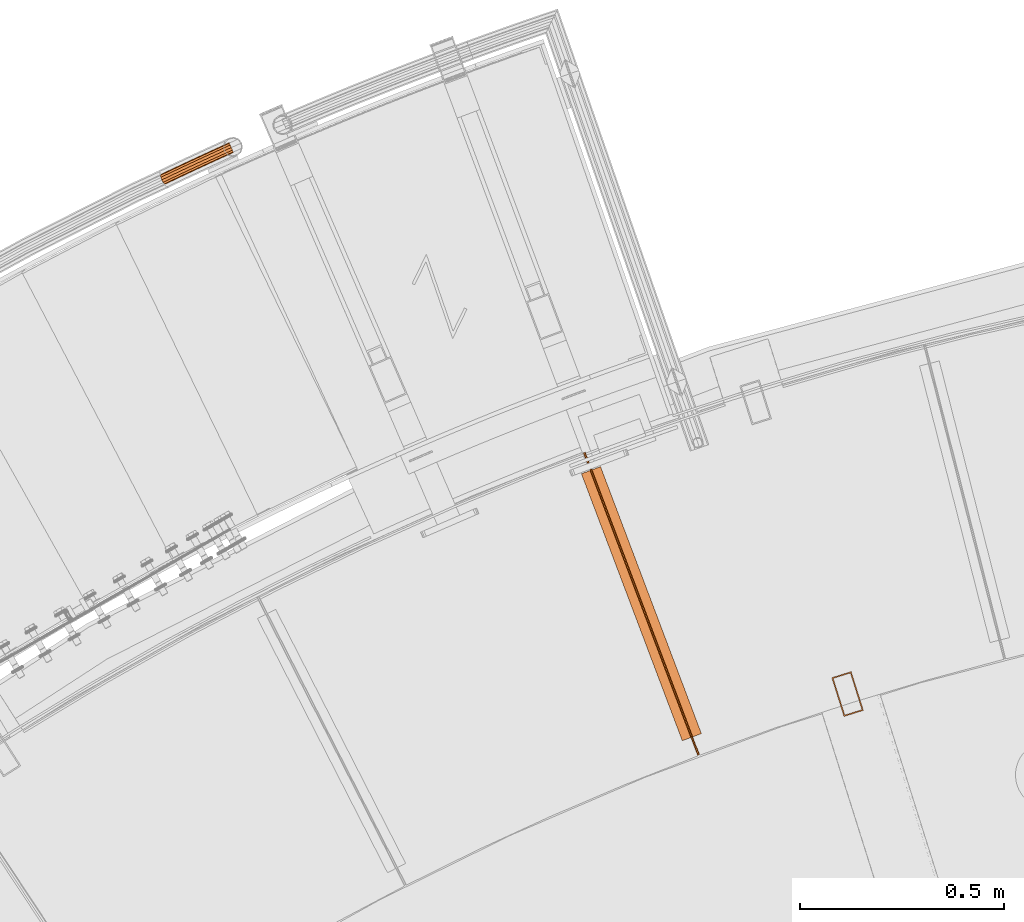
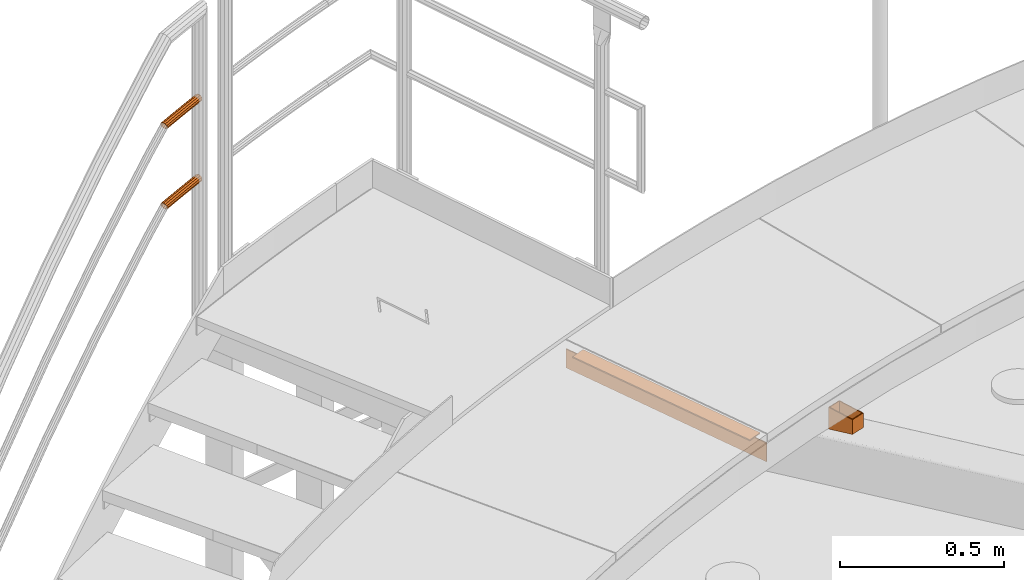
# One storey, part 85 of 126: 5 proxies.
"""IFC2X3 building model written with IfcOpenShell, lengths in millimetres."""

import ifcopenshell
import ifcopenshell.guid

model = None  # the IFC model being written
_history = None  # IfcOwnerHistory: only IFC2X3 demands one
_inside = {}  # id of a spatial element -> (the spatial element, [elements in it])
_under = {}  # id of a project, library or spatial element -> (it, [spatial elements below it])
_declared = {}  # id of a project -> (the project, [libraries it declares])
_typed = {}  # id of a type object -> (the type object, [elements of that type])
_made_of = {}  # id of a material, layer set ... -> (it, [elements and type objects made of it])


def new_model(schema):
    """Start an empty IFC model of exactly this schema.

    Asked for "IFC4X3", IfcOpenShell would pick the latest addendum, in which some entities
    have other attributes; the version numbers below select the first issue.
    IFC2X3 requires an IfcOwnerHistory on every rooted entity: one is made here for all.
    """
    global model, _history
    if schema == "IFC4X3":
        model = ifcopenshell.file(schema_version=(4, 3, 0, 0))
    else:
        model = ifcopenshell.file(schema=schema)
    _inside.clear()
    _under.clear()
    _declared.clear()
    _typed.clear()
    _made_of.clear()
    _history = None
    if model.schema == "IFC2X3":
        org = make("IfcOrganization", Name="unknown")
        user = make(
            "IfcPersonAndOrganization",
            ThePerson=make("IfcPerson", FamilyName="unknown"),
            TheOrganization=org,
        )
        app = make(
            "IfcApplication",
            ApplicationDeveloper=org,
            Version="unknown",
            ApplicationFullName="unknown",
            ApplicationIdentifier="unknown",
        )
        _history = make(
            "IfcOwnerHistory",
            OwningUser=user,
            OwningApplication=app,
            ChangeAction="ADDED",
            CreationDate=0,
        )
    return model


def make(cls, **values):
    """One entity of the class cls with the attributes given. An attribute that is None is left unset."""
    return model.create_entity(
        cls, **{name: value for name, value in values.items() if value is not None}
    )


def rooted(cls, **values):
    """An entity with a GlobalId (a new one), such as an element, a storey or a relation."""
    return make(cls, GlobalId=ifcopenshell.guid.new(), OwnerHistory=_history, **values)


def si_unit(unit_type, name, prefix=None):
    """IfcSIUnit, for example si_unit("LENGTHUNIT", "METRE", prefix="MILLI")."""
    return make("IfcSIUnit", UnitType=unit_type, Prefix=prefix, Name=name)


def assignment(units):
    """IfcUnitAssignment: the units of a project."""
    return None if units is None else make("IfcUnitAssignment", Units=units)


def point(xyz):
    """IfcCartesianPoint."""
    return None if xyz is None else make("IfcCartesianPoint", Coordinates=xyz)


def direction(xyz):
    """IfcDirection."""
    return None if xyz is None else make("IfcDirection", DirectionRatios=xyz)


def frame(location, z_axis=None, x_axis=None):
    """IfcAxis2Placement3D, a coordinate frame: its origin and axes. An axis left out is left unset."""
    return make(
        "IfcAxis2Placement3D",
        Location=point(location),
        Axis=direction(z_axis),
        RefDirection=direction(x_axis),
    )


def origin():
    """The frame at (0, 0, 0) with its axes left unset."""
    return frame((0.0, 0.0, 0.0))


def origin_with_axes():
    """The frame at (0, 0, 0) with the z axis (0, 0, 1) and the x axis (1, 0, 0) written out."""
    return frame((0.0, 0.0, 0.0), z_axis=(0.0, 0.0, 1.0), x_axis=(1.0, 0.0, 0.0))


def place(relative_to, where):
    """IfcLocalPlacement: puts the frame where relative to a parent placement (None: the world)."""
    return make(
        "IfcLocalPlacement", PlacementRelTo=relative_to, RelativePlacement=where
    )


def context(
    kind, dimensions, precision=None, world=None, true_north=None, identifier=None
):
    """IfcGeometricRepresentationContext, for example the 3D "Model" context."""
    return make(
        "IfcGeometricRepresentationContext",
        ContextIdentifier=identifier,
        ContextType=kind,
        CoordinateSpaceDimension=dimensions,
        Precision=precision,
        WorldCoordinateSystem=world,
        TrueNorth=true_north,
    )


def project(units=None, contexts=None):
    """IfcProject with its units and contexts."""
    return rooted(
        "IfcProject",
        Name="project",
        RepresentationContexts=contexts,
        UnitsInContext=assignment(units),
    )


def spatial(cls, under=None, at=None, **own):
    """A site, building, storey or space (cls), placed at a placement, below another one or the project."""
    s = rooted(cls, ObjectPlacement=at, **own)
    if under is not None:
        _under.setdefault(under.id(), (under, []))[1].append(s)
    return s


def faces_of(points, faces, orient=None, outer=None):
    """IfcFace entities. A face is a list of loops; a loop is a list of indices into points, from 0.

    orient and outer hold one flag for each loop. By default every Orientation is true, the
    first loop of a face is its IfcFaceOuterBound and the others are IfcFaceBound.
    """
    made = []
    for i, loops in enumerate(faces):
        bounds = []
        for j, loop in enumerate(loops):
            is_outer = j == 0 if outer is None else outer[i][j]
            bounds.append(
                make(
                    "IfcFaceOuterBound" if is_outer else "IfcFaceBound",
                    Bound=make("IfcPolyLoop", Polygon=[points[k] for k in loop]),
                    Orientation=True if orient is None else orient[i][j],
                )
            )
        made.append(make("IfcFace", Bounds=bounds))
    return made


def faceted_brep(points, faces, orient=None, outer=None, voids=None):
    """IfcFacetedBrep: a solid bounded by flat faces; with voids (closed shells), ...WithVoids."""
    shared = [point(p) for p in points]
    hull = make("IfcClosedShell", CfsFaces=faces_of(shared, faces, orient, outer))
    if voids is None:
        return make("IfcFacetedBrep", Outer=hull)
    return make(
        "IfcFacetedBrepWithVoids",
        Outer=hull,
        Voids=[
            make(cls, CfsFaces=faces_of(shared, fs, o, b)) for cls, fs, o, b in voids
        ],
    )


def shape(context_of_items, identifier, shape_type, items):
    """IfcShapeRepresentation: the items that make up one representation, for example the "Body"."""
    return make(
        "IfcShapeRepresentation",
        ContextOfItems=context_of_items,
        RepresentationIdentifier=identifier,
        RepresentationType=shape_type,
        Items=items,
    )


def material(Name=None, Category=None):
    """IfcMaterial."""
    return make("IfcMaterial", Name=Name, Category=Category)


def made_of(thing, what):
    """Note that an element or type object is made of a material, layer set ...; save() writes the relation."""
    if what is not None:
        _made_of.setdefault(what.id(), (what, []))[1].append(thing)
    return thing


def element(
    cls,
    number,
    at=None,
    inside=None,
    cuts=None,
    type_object=None,
    material=None,
    context=None,
    identifier="Body",
    shape_type=None,
    held_by="IfcProductDefinitionShape",
    body=None,
    shapes=None,
    **own,
):
    """One element of the class cls, such as IfcWall. Its Tag is "e" and its number.

    at: its placement. inside: the storey or other place that contains it. cuts: it is an
    opening in that element (IfcRelVoidsElement). A single representation is given by context,
    identifier, shape_type and body (its items); several are given by shapes. held_by: the class
    of the entity that holds the representations. save() writes the other relations.
    """
    e = rooted(cls, Tag="e%d" % number, ObjectPlacement=at, **own)
    if body is not None:
        shapes = [shape(context, identifier, shape_type, body)]
    if shapes is not None:
        e.Representation = make(held_by, Representations=shapes)
    if inside is not None:
        _inside.setdefault(inside.id(), (inside, []))[1].append(e)
    if cuts is not None:
        rooted(
            "IfcRelVoidsElement", RelatingBuildingElement=cuts, RelatedOpeningElement=e
        )
    if type_object is not None:
        _typed.setdefault(type_object.id(), (type_object, []))[1].append(e)
    return made_of(e, material)


def aggregate(whole, parts):
    """IfcRelAggregates: a whole, such as a stair, and the parts it consists of."""
    return rooted("IfcRelAggregates", RelatingObject=whole, RelatedObjects=parts)


def save(model, path):
    """Write the relations noted so far, then the file.

    IfcRelAggregates (storeys below a building ...), IfcRelContainedInSpatialStructure (elements
    in a storey), IfcRelDefinesByType, IfcRelAssociatesMaterial and IfcRelDeclares: one each for
    every whole, place, type object, material and project.
    """
    for whole, parts in _under.values():
        aggregate(whole, parts)
    for where, things in _inside.values():
        rooted(
            "IfcRelContainedInSpatialStructure",
            RelatedElements=things,
            RelatingStructure=where,
        )
    for kind, things in _typed.values():
        rooted("IfcRelDefinesByType", RelatedObjects=things, RelatingType=kind)
    for what, things in _made_of.values():
        rooted("IfcRelAssociatesMaterial", RelatedObjects=things, RelatingMaterial=what)
    for by, libraries in _declared.values():
        rooted("IfcRelDeclares", RelatingContext=by, RelatedDefinitions=libraries)
    model.write(path)


model = new_model("IFC2X3")

# Units and contexts
context_of_model_1 = context(None, 3, precision=0.1, world=origin())
context_of_model_2 = context(None, 3, precision=0.1, world=origin())
ifc_project = project(units=[si_unit("LENGTHUNIT", "METRE", prefix="MILLI"), si_unit("AREAUNIT", "SQUARE_METRE", prefix="CENTI"), si_unit("VOLUMEUNIT", "CUBIC_METRE", prefix="CENTI"), si_unit("MASSUNIT", "GRAM", prefix="KILO")], contexts=[context_of_model_1, context_of_model_2])

# Site, building, storey
site_placement = place(None, origin_with_axes())
site = spatial("IfcSite", under=ifc_project, at=site_placement, CompositionType="ELEMENT")
building_placement = place(site_placement, origin_with_axes())
building = spatial("IfcBuilding", under=site, at=building_placement, CompositionType="ELEMENT")
storey_placement = place(building_placement, origin_with_axes())
storey = spatial("IfcBuildingStorey", under=building, at=storey_placement, CompositionType="ELEMENT")

# Proxies
ifc_material_1 = material(Name="STAHL")
proxy_1_placement = place(storey_placement, origin_with_axes())
element("IfcBuildingElementProxy", 1, at=proxy_1_placement, inside=storey, material=ifc_material_1, Name="profile", context=context_of_model_2, shape_type="Brep", body=[
    faceted_brep([(5840.1, 14788.1, 10873.4), (5870.1, 14692.7, 10900.2), (5870.1, 14692.7, 10955.2), (5840.1, 14788.1, 10955.2), (5917.8, 14707.8, 10900.2), (5917.8, 14707.8, 10955.2), (5887.8, 14803.1, 10873.4), (5887.8, 14803.1, 10955.2), (5872.1, 14696.5, 10899.4), (5843.8, 14786.2, 10874.2), (5843.8, 14786.2, 10955.2), (5872.1, 14696.5, 10955.2), (5885.8, 14799.4, 10874.2), (5885.8, 14799.4, 10955.2), (5914.1, 14709.7, 10899.4), (5914.1, 14709.7, 10955.2)], [[[0, 1, 2, 3]], [[1, 4, 5, 2]], [[4, 6, 7, 5]], [[6, 0, 3, 7]], [[8, 9, 10, 11]], [[9, 12, 13, 10]], [[12, 14, 15, 13]], [[14, 8, 11, 15]], [[1, 0, 6, 4], [9, 8, 14, 12]], [[2, 5, 7, 3], [15, 11, 10, 13]]]),
])
proxy_2_placement = place(storey_placement, origin_with_axes())
element("IfcBuildingElementProxy", 2, at=proxy_2_placement, inside=storey, material=ifc_material_1, Name="profile", context=context_of_model_2, shape_type="Brep", body=[
    faceted_brep([(5515.2, 14599.7, 11051.2), (5515.2, 14599.7, 10981.2), (5235.3, 15340.5, 10981.2), (5235.3, 15340.5, 11051.2), (5511.5, 14598.2, 10981.2), (5231.5, 15339.1, 10981.2), (5511.5, 14598.2, 11051.2), (5231.5, 15339.1, 11051.2)], [[[0, 1, 2, 3]], [[1, 4, 5, 2]], [[4, 6, 7, 5]], [[6, 0, 3, 7]], [[1, 0, 6, 4]], [[7, 3, 2, 5]]]),
])
proxy_3_placement = place(storey_placement, origin_with_axes())
element("IfcBuildingElementProxy", 3, at=proxy_3_placement, inside=storey, material=ifc_material_1, Name="profile", context=context_of_model_2, shape_type="Brep", body=[
    faceted_brep([(5473.6, 14633.3, 11055.2), (5520.4, 14651.0, 11055.2), (5273.0, 15305.8, 11055.2), (5226.2, 15288.1, 11055.2), (5520.4, 14651.0, 11051.2), (5273.0, 15305.8, 11051.2), (5473.6, 14633.3, 11051.2), (5226.2, 15288.1, 11051.2)], [[[0, 1, 2, 3]], [[1, 4, 5, 2]], [[4, 6, 7, 5]], [[6, 0, 3, 7]], [[1, 0, 6, 4]], [[7, 3, 2, 5]]]),
])
ifc_material_2 = material(Name="S235JRG2")
proxy_4_placement = place(storey_placement, origin_with_axes())
element("IfcBuildingElementProxy", 4, at=proxy_4_placement, inside=storey, material=ifc_material_2, context=context_of_model_2, shape_type="Brep", body=[
    faceted_brep([(4351.7448, 16095.782, 11838.155), (4362.383, 16100.584, 11838.155), (4363.0842, 16098.923, 11831.43), (4352.489, 16094.141, 11831.43), (4364.9998, 16094.386, 11826.507), (4354.5222, 16089.657, 11826.507), (4367.6166, 16088.189, 11824.705), (4357.2995, 16083.532, 11824.705), (4370.2334, 16081.992, 11826.507), (4360.0768, 16077.408, 11826.507), (4372.1491, 16077.455, 11831.43), (4362.1099, 16072.924, 11831.43), (4372.8502, 16075.795, 11838.155), (4362.8541, 16071.283, 11838.155), (4372.1491, 16077.455, 11844.88), (4362.1099, 16072.924, 11844.88), (4370.2334, 16081.992, 11849.803), (4360.0768, 16077.408, 11849.803), (4367.6166, 16088.189, 11851.605), (4357.2995, 16083.532, 11851.605), (4364.9998, 16094.386, 11849.803), (4354.5222, 16089.657, 11849.803), (4363.0842, 16098.923, 11844.88), (4352.489, 16094.141, 11844.88), (4352.5708, 16093.96, 11838.155), (4363.1612, 16098.741, 11838.155), (4363.7581, 16097.327, 11843.88), (4353.2043, 16092.563, 11843.88), (4365.3889, 16093.465, 11848.071), (4354.9351, 16088.746, 11848.071), (4367.6166, 16088.189, 11849.605), (4357.2995, 16083.532, 11849.605), (4369.8443, 16082.914, 11848.071), (4359.6638, 16078.318, 11848.071), (4371.4751, 16079.052, 11843.88), (4361.3946, 16074.502, 11843.88), (4372.072, 16077.638, 11838.155), (4362.0281, 16073.104, 11838.155), (4371.4751, 16079.052, 11832.43), (4361.3946, 16074.502, 11832.43), (4369.8443, 16082.914, 11828.239), (4359.6638, 16078.318, 11828.239), (4367.6166, 16088.189, 11826.705), (4357.2995, 16083.532, 11826.705), (4365.3889, 16093.465, 11828.239), (4354.9351, 16088.746, 11828.239), (4363.7581, 16097.327, 11832.43), (4353.2043, 16092.563, 11832.43), (4324.295, 16081.297, 11831.43), (4323.5451, 16082.935, 11838.155), (4326.3438, 16076.82, 11826.507), (4329.1424, 16070.705, 11824.705), (4331.9411, 16064.59, 11826.507), (4333.9899, 16060.114, 11831.43), (4334.7398, 16058.475, 11838.155), (4333.9899, 16060.114, 11844.88), (4331.9411, 16064.59, 11849.803), (4329.1424, 16070.705, 11851.605), (4326.3438, 16076.82, 11849.803), (4324.295, 16081.297, 11844.88), (4325.0158, 16079.722, 11843.88), (4324.3774, 16081.117, 11838.155), (4326.7599, 16075.911, 11848.071), (4329.1424, 16070.705, 11849.605), (4331.525, 16065.5, 11848.071), (4333.2691, 16061.689, 11843.88), (4333.9075, 16060.294, 11838.155), (4333.2691, 16061.689, 11832.43), (4331.525, 16065.5, 11828.239), (4329.1424, 16070.705, 11826.705), (4326.7599, 16075.911, 11828.239), (4325.0158, 16079.722, 11832.43), (4296.146, 16068.354, 11831.43), (4295.3903, 16069.99, 11838.155), (4298.2103, 16063.885, 11826.507), (4301.0303, 16057.78, 11824.705), (4303.8504, 16051.674, 11826.507), (4305.9147, 16047.205, 11831.43), (4306.6704, 16045.569, 11838.155), (4305.9147, 16047.205, 11844.88), (4303.8504, 16051.674, 11849.803), (4301.0303, 16057.78, 11851.605), (4298.2103, 16063.885, 11849.803), (4296.146, 16068.354, 11844.88), (4296.8723, 16066.782, 11843.88), (4296.229, 16068.174, 11838.155), (4298.6297, 16062.977, 11848.071), (4301.0303, 16057.78, 11849.605), (4303.431, 16052.582, 11848.071), (4305.1884, 16048.778, 11843.88), (4305.8317, 16047.385, 11838.155), (4305.1884, 16048.778, 11832.43), (4303.431, 16052.582, 11828.239), (4301.0303, 16057.78, 11826.705), (4298.6297, 16062.977, 11828.239), (4296.8723, 16066.782, 11832.43), (4268.0423, 16055.313, 11831.43), (4267.281, 16056.947, 11838.155), (4270.1223, 16050.851, 11826.507), (4272.9636, 16044.756, 11824.705), (4275.8048, 16038.661, 11826.507), (4277.8848, 16034.199, 11831.43), (4278.6461, 16032.565, 11838.155), (4277.8848, 16034.199, 11844.88), (4275.8048, 16038.661, 11849.803), (4272.9636, 16044.756, 11851.605), (4270.1223, 16050.851, 11849.803), (4268.0423, 16055.313, 11844.88), (4268.7741, 16053.744, 11843.88), (4268.126, 16055.134, 11838.155), (4270.5448, 16049.945, 11848.071), (4272.9636, 16044.756, 11849.605), (4275.3824, 16039.567, 11848.071), (4277.153, 16035.769, 11843.88), (4277.8012, 16034.378, 11838.155), (4277.153, 16035.769, 11832.43), (4275.3824, 16039.567, 11828.239), (4272.9636, 16044.756, 11826.705), (4270.5448, 16049.945, 11828.239), (4268.7741, 16053.744, 11832.43), (4239.9843, 16042.175, 11831.43), (4239.2173, 16043.805, 11838.155), (4242.0798, 16037.72, 11826.507), (4244.9424, 16031.635, 11824.705), (4247.8049, 16025.549, 11826.507), (4249.9005, 16021.094, 11831.43), (4250.6675, 16019.464, 11838.155), (4249.9005, 16021.094, 11844.88), (4247.8049, 16025.549, 11849.803), (4244.9424, 16031.635, 11851.605), (4242.0798, 16037.72, 11849.803), (4239.9843, 16042.175, 11844.88), (4240.7216, 16040.607, 11843.88), (4240.0686, 16041.995, 11838.155), (4242.5055, 16036.815, 11848.071), (4244.9424, 16031.635, 11849.605), (4247.3793, 16026.454, 11848.071), (4249.1632, 16022.662, 11843.88), (4249.8162, 16021.273, 11838.155), (4249.1632, 16022.662, 11832.43), (4247.3793, 16026.454, 11828.239), (4244.9424, 16031.635, 11826.705), (4242.5055, 16036.815, 11828.239), (4240.7216, 16040.607, 11832.43), (4211.9723, 16028.938, 11831.43), (4211.1996, 16030.566, 11838.155), (4214.0834, 16024.491, 11826.507), (4216.9672, 16018.415, 11824.705), (4219.851, 16012.34, 11826.507), (4221.962, 16007.893, 11831.43), (4222.7348, 16006.265, 11838.155), (4221.962, 16007.893, 11844.88), (4219.851, 16012.34, 11849.803), (4216.9672, 16018.415, 11851.605), (4214.0834, 16024.491, 11849.803), (4211.9723, 16028.938, 11844.88), (4212.7151, 16027.373, 11843.88), (4212.0573, 16028.759, 11838.155), (4214.5122, 16023.587, 11848.071), (4216.9672, 16018.415, 11849.605), (4219.4222, 16013.243, 11848.071), (4221.2193, 16009.457, 11843.88), (4221.8771, 16008.071, 11838.155), (4221.2193, 16009.457, 11832.43), (4219.4222, 16013.243, 11828.239), (4216.9672, 16018.415, 11826.705), (4214.5122, 16023.587, 11828.239), (4212.7151, 16027.373, 11832.43), (4197.8647, 16022.211, 11831.43), (4195.2151, 16022.944, 11838.155), (4201.2603, 16018.376, 11826.507), (4204.4919, 16012.467, 11824.705), (4206.6938, 16006.066, 11826.507), (4207.2758, 16000.89, 11831.43), (4206.0821, 15998.324, 11838.155), (4203.4325, 15999.057, 11844.88), (4200.0369, 16002.892, 11849.803), (4196.8053, 16008.802, 11851.605), (4194.6034, 16015.202, 11849.803), (4194.0214, 16020.379, 11844.88), (4195.0069, 16018.93, 11843.88), (4196.0231, 16021.114, 11838.155), (4195.5023, 16014.523, 11848.071), (4197.3768, 16009.074, 11849.605), (4200.1279, 16004.044, 11848.071), (4203.0185, 16000.779, 11843.88), (4205.2741, 16000.155, 11838.155), (4206.2904, 16002.339, 11832.43), (4205.7949, 16006.746, 11828.239), (4203.9204, 16012.194, 11826.705), (4201.1693, 16017.225, 11828.239), (4198.2787, 16020.49, 11832.43)], [[[0, 1, 2, 3]], [[3, 2, 4, 5]], [[5, 4, 6, 7]], [[7, 6, 8, 9]], [[9, 8, 10, 11]], [[11, 10, 12, 13]], [[13, 12, 14, 15]], [[15, 14, 16, 17]], [[17, 16, 18, 19]], [[19, 18, 20, 21]], [[21, 20, 22, 23]], [[0, 23, 22, 1]], [[24, 25, 26, 27]], [[27, 26, 28, 29]], [[29, 28, 30, 31]], [[31, 30, 32, 33]], [[33, 32, 34, 35]], [[35, 34, 36, 37]], [[37, 36, 38, 39]], [[39, 38, 40, 41]], [[41, 40, 42, 43]], [[43, 42, 44, 45]], [[45, 44, 46, 47]], [[24, 47, 46, 25]], [[0, 3, 48, 49]], [[3, 5, 50, 48]], [[5, 7, 51, 50]], [[7, 9, 52, 51]], [[9, 11, 53, 52]], [[11, 13, 54, 53]], [[13, 15, 55, 54]], [[15, 17, 56, 55]], [[17, 19, 57, 56]], [[19, 21, 58, 57]], [[21, 23, 59, 58]], [[23, 0, 49, 59]], [[24, 27, 60, 61]], [[27, 29, 62, 60]], [[29, 31, 63, 62]], [[31, 33, 64, 63]], [[33, 35, 65, 64]], [[35, 37, 66, 65]], [[37, 39, 67, 66]], [[39, 41, 68, 67]], [[41, 43, 69, 68]], [[43, 45, 70, 69]], [[45, 47, 71, 70]], [[47, 24, 61, 71]], [[49, 48, 72, 73]], [[48, 50, 74, 72]], [[50, 51, 75, 74]], [[51, 52, 76, 75]], [[52, 53, 77, 76]], [[53, 54, 78, 77]], [[54, 55, 79, 78]], [[55, 56, 80, 79]], [[56, 57, 81, 80]], [[57, 58, 82, 81]], [[58, 59, 83, 82]], [[59, 49, 73, 83]], [[61, 60, 84, 85]], [[60, 62, 86, 84]], [[62, 63, 87, 86]], [[63, 64, 88, 87]], [[64, 65, 89, 88]], [[65, 66, 90, 89]], [[66, 67, 91, 90]], [[67, 68, 92, 91]], [[68, 69, 93, 92]], [[69, 70, 94, 93]], [[70, 71, 95, 94]], [[71, 61, 85, 95]], [[73, 72, 96, 97]], [[72, 74, 98, 96]], [[74, 75, 99, 98]], [[75, 76, 100, 99]], [[76, 77, 101, 100]], [[77, 78, 102, 101]], [[78, 79, 103, 102]], [[79, 80, 104, 103]], [[80, 81, 105, 104]], [[81, 82, 106, 105]], [[82, 83, 107, 106]], [[83, 73, 97, 107]], [[85, 84, 108, 109]], [[84, 86, 110, 108]], [[86, 87, 111, 110]], [[87, 88, 112, 111]], [[88, 89, 113, 112]], [[89, 90, 114, 113]], [[90, 91, 115, 114]], [[91, 92, 116, 115]], [[92, 93, 117, 116]], [[93, 94, 118, 117]], [[94, 95, 119, 118]], [[95, 85, 109, 119]], [[97, 96, 120, 121]], [[96, 98, 122, 120]], [[98, 99, 123, 122]], [[99, 100, 124, 123]], [[100, 101, 125, 124]], [[101, 102, 126, 125]], [[102, 103, 127, 126]], [[103, 104, 128, 127]], [[104, 105, 129, 128]], [[105, 106, 130, 129]], [[106, 107, 131, 130]], [[107, 97, 121, 131]], [[109, 108, 132, 133]], [[108, 110, 134, 132]], [[110, 111, 135, 134]], [[111, 112, 136, 135]], [[112, 113, 137, 136]], [[113, 114, 138, 137]], [[114, 115, 139, 138]], [[115, 116, 140, 139]], [[116, 117, 141, 140]], [[117, 118, 142, 141]], [[118, 119, 143, 142]], [[119, 109, 133, 143]], [[121, 120, 144, 145]], [[120, 122, 146, 144]], [[122, 123, 147, 146]], [[123, 124, 148, 147]], [[124, 125, 149, 148]], [[125, 126, 150, 149]], [[126, 127, 151, 150]], [[127, 128, 152, 151]], [[128, 129, 153, 152]], [[129, 130, 154, 153]], [[130, 131, 155, 154]], [[131, 121, 145, 155]], [[133, 132, 156, 157]], [[132, 134, 158, 156]], [[134, 135, 159, 158]], [[135, 136, 160, 159]], [[136, 137, 161, 160]], [[137, 138, 162, 161]], [[138, 139, 163, 162]], [[139, 140, 164, 163]], [[140, 141, 165, 164]], [[141, 142, 166, 165]], [[142, 143, 167, 166]], [[143, 133, 157, 167]], [[144, 168, 169, 145]], [[144, 146, 170, 168]], [[146, 147, 171, 170]], [[147, 148, 172, 171]], [[148, 149, 173, 172]], [[149, 150, 174, 173]], [[150, 151, 175, 174]], [[151, 152, 176, 175]], [[152, 153, 177, 176]], [[153, 154, 178, 177]], [[154, 155, 179, 178]], [[145, 169, 179, 155]], [[156, 180, 181, 157]], [[156, 158, 182, 180]], [[158, 159, 183, 182]], [[159, 160, 184, 183]], [[160, 161, 185, 184]], [[161, 162, 186, 185]], [[162, 163, 187, 186]], [[163, 164, 188, 187]], [[164, 165, 189, 188]], [[165, 166, 190, 189]], [[166, 167, 191, 190]], [[157, 181, 191, 167]], [[6, 4, 2, 1, 22, 20, 18, 16, 14, 12, 10, 8], [26, 25, 46, 44, 42, 40, 38, 36, 34, 32, 30, 28]], [[177, 178, 179, 169, 168, 170, 171, 172, 173, 174, 175, 176], [180, 182, 183, 184, 185, 186, 187, 188, 189, 190, 191, 181]]]),
])
proxy_5_placement = place(storey_placement, origin_with_axes())
element("IfcBuildingElementProxy", 5, at=proxy_5_placement, inside=storey, material=ifc_material_2, context=context_of_model_2, shape_type="Brep", body=[
    faceted_brep([(4351.7448, 16095.782, 11538.155), (4362.383, 16100.584, 11538.155), (4363.0842, 16098.923, 11531.43), (4352.489, 16094.141, 11531.43), (4364.9998, 16094.386, 11526.507), (4354.5222, 16089.657, 11526.507), (4367.6166, 16088.189, 11524.705), (4357.2995, 16083.532, 11524.705), (4370.2334, 16081.992, 11526.507), (4360.0768, 16077.408, 11526.507), (4372.1491, 16077.455, 11531.43), (4362.1099, 16072.924, 11531.43), (4372.8502, 16075.795, 11538.155), (4362.8541, 16071.283, 11538.155), (4372.1491, 16077.455, 11544.88), (4362.1099, 16072.924, 11544.88), (4370.2334, 16081.992, 11549.803), (4360.0768, 16077.408, 11549.803), (4367.6166, 16088.189, 11551.605), (4357.2995, 16083.532, 11551.605), (4364.9998, 16094.386, 11549.803), (4354.5222, 16089.657, 11549.803), (4363.0842, 16098.923, 11544.88), (4352.489, 16094.141, 11544.88), (4352.5708, 16093.96, 11538.155), (4363.1612, 16098.741, 11538.155), (4363.7581, 16097.327, 11543.88), (4353.2043, 16092.563, 11543.88), (4365.3889, 16093.465, 11548.071), (4354.9351, 16088.746, 11548.071), (4367.6166, 16088.189, 11549.605), (4357.2995, 16083.532, 11549.605), (4369.8443, 16082.914, 11548.071), (4359.6638, 16078.318, 11548.071), (4371.4751, 16079.052, 11543.88), (4361.3946, 16074.502, 11543.88), (4372.072, 16077.638, 11538.155), (4362.0281, 16073.104, 11538.155), (4371.4751, 16079.052, 11532.43), (4361.3946, 16074.502, 11532.43), (4369.8443, 16082.914, 11528.239), (4359.6638, 16078.318, 11528.239), (4367.6166, 16088.189, 11526.705), (4357.2995, 16083.532, 11526.705), (4365.3889, 16093.465, 11528.239), (4354.9351, 16088.746, 11528.239), (4363.7581, 16097.327, 11532.43), (4353.2043, 16092.563, 11532.43), (4324.295, 16081.297, 11531.43), (4323.5451, 16082.935, 11538.155), (4326.3438, 16076.82, 11526.507), (4329.1424, 16070.705, 11524.705), (4331.9411, 16064.59, 11526.507), (4333.9899, 16060.114, 11531.43), (4334.7398, 16058.475, 11538.155), (4333.9899, 16060.114, 11544.88), (4331.9411, 16064.59, 11549.803), (4329.1424, 16070.705, 11551.605), (4326.3438, 16076.82, 11549.803), (4324.295, 16081.297, 11544.88), (4325.0158, 16079.722, 11543.88), (4324.3774, 16081.117, 11538.155), (4326.7599, 16075.911, 11548.071), (4329.1424, 16070.705, 11549.605), (4331.525, 16065.5, 11548.071), (4333.2691, 16061.689, 11543.88), (4333.9075, 16060.294, 11538.155), (4333.2691, 16061.689, 11532.43), (4331.525, 16065.5, 11528.239), (4329.1424, 16070.705, 11526.705), (4326.7599, 16075.911, 11528.239), (4325.0158, 16079.722, 11532.43), (4296.146, 16068.354, 11531.43), (4295.3903, 16069.99, 11538.155), (4298.2103, 16063.885, 11526.507), (4301.0303, 16057.78, 11524.705), (4303.8504, 16051.674, 11526.507), (4305.9147, 16047.205, 11531.43), (4306.6704, 16045.569, 11538.155), (4305.9147, 16047.205, 11544.88), (4303.8504, 16051.674, 11549.803), (4301.0303, 16057.78, 11551.605), (4298.2103, 16063.885, 11549.803), (4296.146, 16068.354, 11544.88), (4296.8723, 16066.782, 11543.88), (4296.229, 16068.174, 11538.155), (4298.6297, 16062.977, 11548.071), (4301.0303, 16057.78, 11549.605), (4303.431, 16052.582, 11548.071), (4305.1884, 16048.778, 11543.88), (4305.8317, 16047.385, 11538.155), (4305.1884, 16048.778, 11532.43), (4303.431, 16052.582, 11528.239), (4301.0303, 16057.78, 11526.705), (4298.6297, 16062.977, 11528.239), (4296.8723, 16066.782, 11532.43), (4268.0423, 16055.313, 11531.43), (4267.281, 16056.947, 11538.155), (4270.1223, 16050.851, 11526.507), (4272.9636, 16044.756, 11524.705), (4275.8048, 16038.661, 11526.507), (4277.8848, 16034.199, 11531.43), (4278.6461, 16032.565, 11538.155), (4277.8848, 16034.199, 11544.88), (4275.8048, 16038.661, 11549.803), (4272.9636, 16044.756, 11551.605), (4270.1223, 16050.851, 11549.803), (4268.0423, 16055.313, 11544.88), (4268.7741, 16053.744, 11543.88), (4268.126, 16055.134, 11538.155), (4270.5448, 16049.945, 11548.071), (4272.9636, 16044.756, 11549.605), (4275.3824, 16039.567, 11548.071), (4277.153, 16035.769, 11543.88), (4277.8012, 16034.378, 11538.155), (4277.153, 16035.769, 11532.43), (4275.3824, 16039.567, 11528.239), (4272.9636, 16044.756, 11526.705), (4270.5448, 16049.945, 11528.239), (4268.7741, 16053.744, 11532.43), (4239.9843, 16042.175, 11531.43), (4239.2173, 16043.805, 11538.155), (4242.0798, 16037.72, 11526.507), (4244.9424, 16031.635, 11524.705), (4247.8049, 16025.549, 11526.507), (4249.9005, 16021.094, 11531.43), (4250.6675, 16019.464, 11538.155), (4249.9005, 16021.094, 11544.88), (4247.8049, 16025.549, 11549.803), (4244.9424, 16031.635, 11551.605), (4242.0798, 16037.72, 11549.803), (4239.9843, 16042.175, 11544.88), (4240.7216, 16040.607, 11543.88), (4240.0686, 16041.995, 11538.155), (4242.5055, 16036.815, 11548.071), (4244.9424, 16031.635, 11549.605), (4247.3793, 16026.454, 11548.071), (4249.1632, 16022.662, 11543.88), (4249.8162, 16021.273, 11538.155), (4249.1632, 16022.662, 11532.43), (4247.3793, 16026.454, 11528.239), (4244.9424, 16031.635, 11526.705), (4242.5055, 16036.815, 11528.239), (4240.7216, 16040.607, 11532.43), (4211.9723, 16028.938, 11531.43), (4211.1996, 16030.566, 11538.155), (4214.0834, 16024.491, 11526.507), (4216.9672, 16018.415, 11524.705), (4219.851, 16012.34, 11526.507), (4221.962, 16007.893, 11531.43), (4222.7348, 16006.265, 11538.155), (4221.962, 16007.893, 11544.88), (4219.851, 16012.34, 11549.803), (4216.9672, 16018.415, 11551.605), (4214.0834, 16024.491, 11549.803), (4211.9723, 16028.938, 11544.88), (4212.7151, 16027.373, 11543.88), (4212.0573, 16028.759, 11538.155), (4214.5122, 16023.587, 11548.071), (4216.9672, 16018.415, 11549.605), (4219.4222, 16013.243, 11548.071), (4221.2193, 16009.457, 11543.88), (4221.8771, 16008.071, 11538.155), (4221.2193, 16009.457, 11532.43), (4219.4222, 16013.243, 11528.239), (4216.9672, 16018.415, 11526.705), (4214.5122, 16023.587, 11528.239), (4212.7151, 16027.373, 11532.43), (4197.8647, 16022.211, 11531.43), (4195.2151, 16022.944, 11538.155), (4201.2603, 16018.376, 11526.507), (4204.4919, 16012.467, 11524.705), (4206.6938, 16006.066, 11526.507), (4207.2758, 16000.89, 11531.43), (4206.0821, 15998.324, 11538.155), (4203.4325, 15999.057, 11544.88), (4200.0369, 16002.892, 11549.803), (4196.8053, 16008.802, 11551.605), (4194.6034, 16015.202, 11549.803), (4194.0214, 16020.379, 11544.88), (4195.0069, 16018.93, 11543.88), (4196.0231, 16021.114, 11538.155), (4195.5023, 16014.523, 11548.071), (4197.3768, 16009.074, 11549.605), (4200.1279, 16004.044, 11548.071), (4203.0185, 16000.779, 11543.88), (4205.2741, 16000.155, 11538.155), (4206.2903, 16002.339, 11532.43), (4205.7949, 16006.746, 11528.239), (4203.9204, 16012.194, 11526.705), (4201.1693, 16017.225, 11528.239), (4198.2787, 16020.49, 11532.43)], [[[0, 1, 2, 3]], [[3, 2, 4, 5]], [[5, 4, 6, 7]], [[7, 6, 8, 9]], [[9, 8, 10, 11]], [[11, 10, 12, 13]], [[13, 12, 14, 15]], [[15, 14, 16, 17]], [[17, 16, 18, 19]], [[19, 18, 20, 21]], [[21, 20, 22, 23]], [[0, 23, 22, 1]], [[24, 25, 26, 27]], [[27, 26, 28, 29]], [[29, 28, 30, 31]], [[31, 30, 32, 33]], [[33, 32, 34, 35]], [[35, 34, 36, 37]], [[37, 36, 38, 39]], [[39, 38, 40, 41]], [[41, 40, 42, 43]], [[43, 42, 44, 45]], [[45, 44, 46, 47]], [[24, 47, 46, 25]], [[0, 3, 48, 49]], [[3, 5, 50, 48]], [[5, 7, 51, 50]], [[7, 9, 52, 51]], [[9, 11, 53, 52]], [[11, 13, 54, 53]], [[13, 15, 55, 54]], [[15, 17, 56, 55]], [[17, 19, 57, 56]], [[19, 21, 58, 57]], [[21, 23, 59, 58]], [[23, 0, 49, 59]], [[24, 27, 60, 61]], [[27, 29, 62, 60]], [[29, 31, 63, 62]], [[31, 33, 64, 63]], [[33, 35, 65, 64]], [[35, 37, 66, 65]], [[37, 39, 67, 66]], [[39, 41, 68, 67]], [[41, 43, 69, 68]], [[43, 45, 70, 69]], [[45, 47, 71, 70]], [[47, 24, 61, 71]], [[49, 48, 72, 73]], [[48, 50, 74, 72]], [[50, 51, 75, 74]], [[51, 52, 76, 75]], [[52, 53, 77, 76]], [[53, 54, 78, 77]], [[54, 55, 79, 78]], [[55, 56, 80, 79]], [[56, 57, 81, 80]], [[57, 58, 82, 81]], [[58, 59, 83, 82]], [[59, 49, 73, 83]], [[61, 60, 84, 85]], [[60, 62, 86, 84]], [[62, 63, 87, 86]], [[63, 64, 88, 87]], [[64, 65, 89, 88]], [[65, 66, 90, 89]], [[66, 67, 91, 90]], [[67, 68, 92, 91]], [[68, 69, 93, 92]], [[69, 70, 94, 93]], [[70, 71, 95, 94]], [[71, 61, 85, 95]], [[73, 72, 96, 97]], [[72, 74, 98, 96]], [[74, 75, 99, 98]], [[75, 76, 100, 99]], [[76, 77, 101, 100]], [[77, 78, 102, 101]], [[78, 79, 103, 102]], [[79, 80, 104, 103]], [[80, 81, 105, 104]], [[81, 82, 106, 105]], [[82, 83, 107, 106]], [[83, 73, 97, 107]], [[85, 84, 108, 109]], [[84, 86, 110, 108]], [[86, 87, 111, 110]], [[87, 88, 112, 111]], [[88, 89, 113, 112]], [[89, 90, 114, 113]], [[90, 91, 115, 114]], [[91, 92, 116, 115]], [[92, 93, 117, 116]], [[93, 94, 118, 117]], [[94, 95, 119, 118]], [[95, 85, 109, 119]], [[97, 96, 120, 121]], [[96, 98, 122, 120]], [[98, 99, 123, 122]], [[99, 100, 124, 123]], [[100, 101, 125, 124]], [[101, 102, 126, 125]], [[102, 103, 127, 126]], [[103, 104, 128, 127]], [[104, 105, 129, 128]], [[105, 106, 130, 129]], [[106, 107, 131, 130]], [[107, 97, 121, 131]], [[109, 108, 132, 133]], [[108, 110, 134, 132]], [[110, 111, 135, 134]], [[111, 112, 136, 135]], [[112, 113, 137, 136]], [[113, 114, 138, 137]], [[114, 115, 139, 138]], [[115, 116, 140, 139]], [[116, 117, 141, 140]], [[117, 118, 142, 141]], [[118, 119, 143, 142]], [[119, 109, 133, 143]], [[121, 120, 144, 145]], [[120, 122, 146, 144]], [[122, 123, 147, 146]], [[123, 124, 148, 147]], [[124, 125, 149, 148]], [[125, 126, 150, 149]], [[126, 127, 151, 150]], [[127, 128, 152, 151]], [[128, 129, 153, 152]], [[129, 130, 154, 153]], [[130, 131, 155, 154]], [[131, 121, 145, 155]], [[133, 132, 156, 157]], [[132, 134, 158, 156]], [[134, 135, 159, 158]], [[135, 136, 160, 159]], [[136, 137, 161, 160]], [[137, 138, 162, 161]], [[138, 139, 163, 162]], [[139, 140, 164, 163]], [[140, 141, 165, 164]], [[141, 142, 166, 165]], [[142, 143, 167, 166]], [[143, 133, 157, 167]], [[144, 168, 169, 145]], [[144, 146, 170, 168]], [[146, 147, 171, 170]], [[147, 148, 172, 171]], [[148, 149, 173, 172]], [[149, 150, 174, 173]], [[150, 151, 175, 174]], [[151, 152, 176, 175]], [[152, 153, 177, 176]], [[153, 154, 178, 177]], [[154, 155, 179, 178]], [[145, 169, 179, 155]], [[156, 180, 181, 157]], [[156, 158, 182, 180]], [[158, 159, 183, 182]], [[159, 160, 184, 183]], [[160, 161, 185, 184]], [[161, 162, 186, 185]], [[162, 163, 187, 186]], [[163, 164, 188, 187]], [[164, 165, 189, 188]], [[165, 166, 190, 189]], [[166, 167, 191, 190]], [[157, 181, 191, 167]], [[6, 4, 2, 1, 22, 20, 18, 16, 14, 12, 10, 8], [26, 25, 46, 44, 42, 40, 38, 36, 34, 32, 30, 28]], [[177, 178, 179, 169, 168, 170, 171, 172, 173, 174, 175, 176], [180, 182, 183, 184, 185, 186, 187, 188, 189, 190, 191, 181]]]),
])

save(model, "model.ifc")
